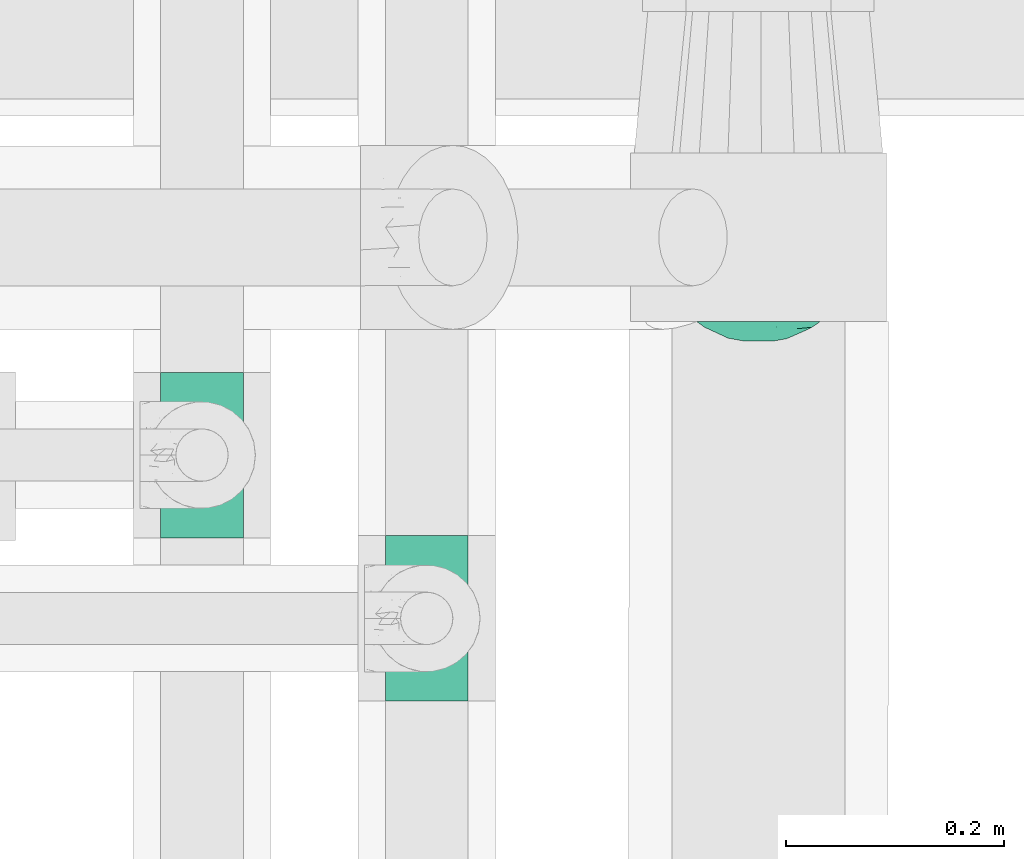
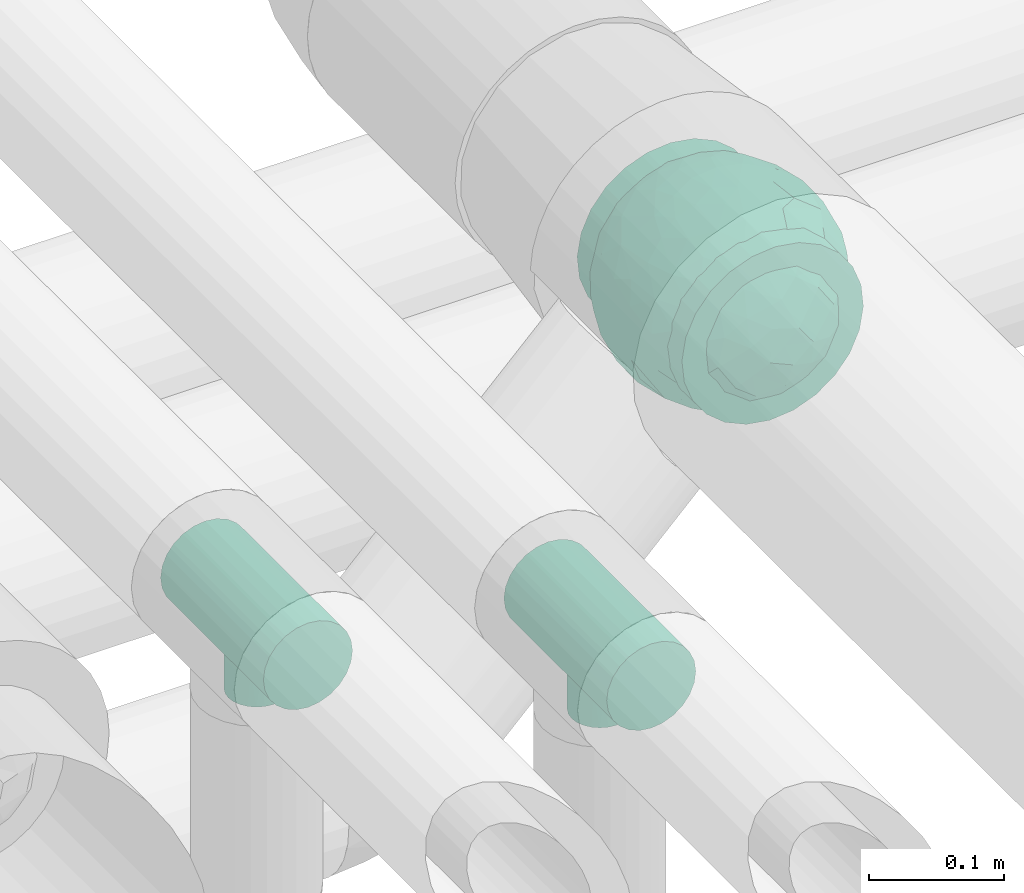
# One storey, part 68 of 93: 3 flow fittings.
"""IFC2X3 building model written with IfcOpenShell, lengths in millimetres."""

from ifc_helpers import new_model, entity, si_unit, converted_unit, derived_unit, direction, frame, origin, place, context, subcontext, project, spatial, faceted_brep, source, transform, mapped, material, material_list, type_object, type_shapes, element, save


model = new_model("IFC2X3")

# Units and contexts
model_context = context("Model", 3, precision=0.01, world=origin(), true_north=direction((6.12303176911189e-17, 1.0)))
body_context = subcontext(model_context, "Body", "Model", "MODEL_VIEW")
ifc_project = project(units=[si_unit("LENGTHUNIT", "METRE", prefix="MILLI"), si_unit("AREAUNIT", "SQUARE_METRE"), si_unit("VOLUMEUNIT", "CUBIC_METRE"), converted_unit("PLANEANGLEUNIT", "DEGREE", entity("IfcRatioMeasure", 0.0174532925199433), si_unit("PLANEANGLEUNIT", "RADIAN"), dimensions=[0, 0, 0, 0, 0, 0, 0]), si_unit("MASSUNIT", "GRAM", prefix="KILO"), derived_unit("MASSDENSITYUNIT", [(si_unit("MASSUNIT", "GRAM", prefix="KILO"), 1), (si_unit("LENGTHUNIT", "METRE"), -3)]), derived_unit("MOMENTOFINERTIAUNIT", [(si_unit("LENGTHUNIT", "METRE"), 4)]), si_unit("TIMEUNIT", "SECOND"), si_unit("FREQUENCYUNIT", "HERTZ"), si_unit("THERMODYNAMICTEMPERATUREUNIT", "DEGREE_CELSIUS"), derived_unit("THERMALTRANSMITTANCEUNIT", [(si_unit("MASSUNIT", "GRAM", prefix="KILO"), 1), (si_unit("THERMODYNAMICTEMPERATUREUNIT", "KELVIN"), -1), (si_unit("TIMEUNIT", "SECOND"), -3)]), derived_unit("VOLUMETRICFLOWRATEUNIT", [(si_unit("LENGTHUNIT", "METRE"), 3), (si_unit("TIMEUNIT", "SECOND"), -1)]), derived_unit("MASSFLOWRATEUNIT", [(si_unit("MASSUNIT", "GRAM", prefix="KILO"), 1), (si_unit("TIMEUNIT", "SECOND"), -1)]), derived_unit("ROTATIONALFREQUENCYUNIT", [(si_unit("TIMEUNIT", "SECOND"), -1)]), si_unit("ELECTRICCURRENTUNIT", "AMPERE"), si_unit("ELECTRICVOLTAGEUNIT", "VOLT"), si_unit("POWERUNIT", "WATT"), si_unit("FORCEUNIT", "NEWTON", prefix="KILO"), si_unit("ILLUMINANCEUNIT", "LUX"), si_unit("LUMINOUSFLUXUNIT", "LUMEN"), si_unit("LUMINOUSINTENSITYUNIT", "CANDELA"), derived_unit("USERDEFINED", [(si_unit("MASSUNIT", "GRAM", prefix="KILO"), -1), (si_unit("LENGTHUNIT", "METRE"), -2), (si_unit("TIMEUNIT", "SECOND"), 3), (si_unit("LUMINOUSFLUXUNIT", "LUMEN"), 1)]), derived_unit("LINEARVELOCITYUNIT", [(si_unit("LENGTHUNIT", "METRE"), 1), (si_unit("TIMEUNIT", "SECOND"), -1)]), si_unit("PRESSUREUNIT", "PASCAL"), derived_unit("USERDEFINED", [(si_unit("LENGTHUNIT", "METRE"), -2), (si_unit("MASSUNIT", "GRAM", prefix="KILO"), 1), (si_unit("TIMEUNIT", "SECOND"), -2)]), derived_unit("LINEARFORCEUNIT", [(si_unit("MASSUNIT", "GRAM", prefix="KILO"), 1), (si_unit("LENGTHUNIT", "METRE"), 1), (si_unit("TIMEUNIT", "SECOND"), -2), (si_unit("LENGTHUNIT", "METRE"), -1)]), derived_unit("PLANARFORCEUNIT", [(si_unit("MASSUNIT", "GRAM", prefix="KILO"), 1), (si_unit("LENGTHUNIT", "METRE"), 1), (si_unit("TIMEUNIT", "SECOND"), -2), (si_unit("LENGTHUNIT", "METRE"), -2)])], contexts=[model_context])

# Site, building, storey
site_placement = place(None, origin())
site = spatial("IfcSite", under=ifc_project, at=site_placement, CompositionType="ELEMENT")
building_placement = place(site_placement, origin())
building = spatial("IfcBuilding", under=site, at=building_placement, CompositionType="ELEMENT")
storey_placement = place(building_placement, frame((0.0, 0.0, -4200.0)))
storey = spatial("IfcBuildingStorey", under=building, at=storey_placement, CompositionType="ELEMENT", Elevation=-4200.0)

# Flow fittings
ifc_material_1 = material()
ifc_material_2 = material(Name="ADSK_")
ifc_material_list = material_list([ifc_material_1, ifc_material_2])
pipe_fitting_type_1 = type_object("IfcPipeFittingType", Name="ADSK_2", PredefinedType="NOTDEFINED", material=ifc_material_list)
shared_shape_1 = source(origin(), body_context, "Body", "Brep", [
    faceted_brep([(-77.5, 38.75, -67.12), (-77.5, 20.06, -74.86), (-77.5, 0.0, -77.5), (-77.5, -20.06, -74.86), (-77.5, -38.75, -67.12), (-77.5, -54.8, -54.8), (-77.5, -67.12, -38.75), (-77.5, -70.99, -29.4), (-77.5, -74.86, -20.06), (-77.5, -76.18, -10.03), (-77.5, -77.5, 0.0), (-77.5, -76.18, 10.03), (-77.5, -74.86, 20.06), (-77.5, -70.99, 29.4), (-77.5, -67.12, 38.75), (-77.5, -54.8, 54.8), (-77.5, -38.75, 67.12), (-77.5, -20.06, 74.86), (-77.5, 0.0, 77.5), (-77.5, 20.06, 74.86), (-77.5, 38.75, 67.12), (-77.5, 54.8, 54.8), (-77.5, 67.12, 38.75), (-77.5, 74.86, 20.06), (-77.5, 77.5, 0.0), (-77.5, 74.86, -20.06), (-77.5, 67.12, -38.75), (-77.5, 54.8, -54.8), (77.5, 0.0, -77.5), (77.5, 20.06, -74.86), (77.5, 38.75, -67.12), (77.5, 54.8, -54.8), (77.5, 67.12, -38.75), (77.5, 74.86, -20.06), (77.5, 77.5, 0.0), (77.5, 74.86, 20.06), (77.5, 67.12, 38.75), (77.5, 54.8, 54.8), (77.5, 38.75, 67.12), (77.5, 20.06, 74.86), (77.5, 0.0, 77.5), (77.5, -20.06, 74.86), (77.5, -38.75, 67.12), (77.5, -54.8, 54.8), (77.5, -67.12, 38.75), (77.5, -70.99, 29.4), (77.5, -74.86, 20.06), (77.5, -76.18, 10.03), (77.5, -77.5, 0.0), (77.5, -76.18, -10.03), (77.5, -74.86, -20.06), (77.5, -70.99, -29.4), (77.5, -67.12, -38.75), (77.5, -54.8, -54.8), (77.5, -38.75, -67.12), (77.5, -20.06, -74.86), (39.85, -76.08, 14.76), (41.18, -76.79, 7.38), (32.47, -72.49, 27.42), (36.16, -74.28, 21.09), (7.52, -65.24, 41.83), (42.5, -77.5, 0.0), (21.39, -68.25, 36.72), (14.46, -66.74, 39.28), (-21.4, -68.25, 36.72), (-32.48, -72.49, 27.41), (-39.86, -76.08, 14.76), (-41.18, -76.79, 7.38), (-42.5, -77.5, 0.0), (-36.17, -74.29, 21.08), (-14.46, -66.75, 39.27), (-7.53, -65.24, 41.83), (-0.01, -65.24, 41.83), (7.52, -65.24, -41.83), (-41.18, -76.79, -7.38), (21.39, -68.25, -36.72), (14.46, -66.74, -39.28), (41.18, -76.79, -7.38), (-39.86, -76.08, -14.76), (39.85, -76.08, -14.76), (36.16, -74.28, -21.09), (32.47, -72.49, -27.42), (-7.53, -65.24, -41.83), (-14.46, -66.75, -39.27), (-21.4, -68.25, -36.72), (-32.48, -72.49, -27.41), (-0.01, -65.24, -41.83), (-36.17, -74.29, -21.08), (11.0, -82.5, -41.05), (21.25, -82.5, -36.81), (30.05, -82.5, -30.05), (36.81, -82.5, -21.25), (41.05, -82.5, -11.0), (41.78, -82.5, -5.5), (42.5, -82.5, 0.0), (41.78, -82.5, 5.5), (41.05, -82.5, 11.0), (36.81, -82.5, 21.25), (30.05, -82.5, 30.05), (21.25, -82.5, 36.81), (11.0, -82.5, 41.05), (0.0, -82.5, 42.5), (-11.0, -82.5, 41.05), (-21.25, -82.5, 36.81), (-30.05, -82.5, 30.05), (-36.81, -82.5, 21.25), (-41.05, -82.5, 11.0), (-41.78, -82.5, 5.5), (-42.5, -82.5, 0.0), (-41.78, -82.5, -5.5), (-41.05, -82.5, -11.0), (-36.81, -82.5, -21.25), (-30.05, -82.5, -30.05), (-21.25, -82.5, -36.81), (-11.0, -82.5, -41.05), (0.0, -82.5, -42.5)], [[[0, 1, 2, 3, 4, 5, 6, 7, 8, 9, 10, 11, 12, 13, 14, 15, 16, 17, 18, 19, 20, 21, 22, 23, 24, 25, 26, 27]], [[28, 29, 30, 31, 32, 33, 34, 35, 36, 37, 38, 39, 40, 41, 42, 43, 44, 45, 46, 47, 48, 49, 50, 51, 52, 53, 54, 55]], [[47, 46, 56]], [[48, 47, 57]], [[46, 58, 59, 56]], [[44, 43, 60]], [[48, 57, 61]], [[58, 45, 62]], [[44, 60, 63, 62]], [[47, 56, 57]], [[43, 15, 60]], [[62, 45, 44]], [[64, 13, 65]], [[66, 11, 67]], [[68, 67, 10]], [[12, 66, 69, 65]], [[14, 64, 70, 71]], [[58, 46, 45]], [[14, 13, 64]], [[14, 71, 15]], [[65, 13, 12]], [[15, 71, 72, 60]], [[10, 67, 11]], [[66, 12, 11]], [[43, 42, 16, 15]], [[18, 17, 41, 40]], [[17, 16, 42, 41]], [[19, 18, 40, 39]], [[36, 35, 23, 22]], [[21, 20, 38, 37]], [[22, 21, 37, 36]], [[39, 38, 20, 19]], [[24, 23, 35, 34]], [[26, 25, 33, 32]], [[25, 24, 34, 33]], [[27, 26, 32, 31]], [[28, 55, 3, 2]], [[1, 0, 30, 29]], [[2, 1, 29, 28]], [[31, 30, 0, 27]], [[4, 3, 55, 54]], [[54, 53, 5, 4]], [[53, 52, 73]], [[10, 74, 68]], [[52, 75, 76, 73]], [[51, 75, 52]], [[53, 73, 5]], [[61, 77, 48]], [[9, 78, 74]], [[50, 79, 80, 81]], [[79, 49, 77]], [[75, 51, 81]], [[50, 81, 51]], [[6, 82, 83, 84]], [[85, 8, 7]], [[6, 5, 82]], [[85, 7, 84]], [[5, 73, 86, 82]], [[8, 85, 87, 78]], [[79, 50, 49]], [[78, 9, 8]], [[74, 10, 9]], [[48, 77, 49]], [[7, 6, 84]], [[88, 89, 90, 91, 92, 93, 94, 95, 96, 97, 98, 99, 100, 101, 102, 103, 104, 105, 106, 107, 108, 109, 110, 111, 112, 113, 114, 115]], [[107, 106, 67]], [[65, 105, 104]], [[106, 105, 66]], [[104, 103, 64]], [[61, 95, 94]], [[107, 68, 108]], [[66, 105, 65, 69]], [[70, 64, 103]], [[64, 65, 104]], [[101, 60, 72, 71]], [[102, 71, 70]], [[102, 70, 103]], [[68, 107, 67]], [[57, 96, 95]], [[60, 101, 100]], [[101, 71, 102]], [[58, 98, 97]], [[99, 98, 62]], [[56, 97, 96]], [[99, 63, 100]], [[98, 58, 62]], [[106, 66, 67]], [[63, 60, 100]], [[96, 57, 56]], [[59, 58, 97, 56]], [[95, 61, 57]], [[63, 99, 62]], [[93, 92, 77]], [[81, 91, 90]], [[92, 91, 79]], [[90, 89, 75]], [[68, 109, 108]], [[93, 61, 94]], [[79, 91, 81, 80]], [[76, 75, 89]], [[75, 81, 90]], [[115, 82, 86, 73]], [[83, 113, 84]], [[88, 76, 89]], [[88, 73, 76]], [[61, 93, 77]], [[82, 115, 114]], [[115, 73, 88]], [[111, 85, 112]], [[74, 110, 109]], [[113, 112, 84]], [[78, 111, 110]], [[113, 83, 114]], [[112, 85, 84]], [[92, 79, 77]], [[110, 74, 78]], [[87, 85, 111, 78]], [[109, 68, 74]], [[83, 82, 114]]]),
    faceted_brep([(74.09, -36.62, -50.54), (86.5, -25.35, -35.5), (82.61, -45.18, -22.81), (-16.75, -33.7, -89.27), (0.0, -42.78, -86.92), (-23.87, -49.97, -79.49), (73.94, -14.61, -60.86), (53.84, -28.63, -75.28), (-16.57, 93.95, 0.0), (-18.09, 86.11, -40.53), (-32.84, 86.73, -28.0), (-44.04, -10.15, -85.69), (-19.2, 4.88, -94.83), (-22.92, -15.62, -92.82), (89.65, 32.63, 0.0), (82.61, 44.34, -24.37), (83.9, 48.44, 0.0), (47.7, -82.62, 0.0), (60.26, -69.94, -29.38), (62.27, -74.21, 0.0), (95.4, 0.0, 0.0), (95.4, -16.82, 0.0), (94.13, -8.44, -21.26), (93.14, 13.95, -22.71), (95.4, 16.82, 0.0), (76.54, 8.21, -58.81), (74.09, 36.62, -50.54), (84.96, 22.7, -40.64), (28.25, -36.42, -85.21), (19.67, -61.78, -71.98), (-67.45, 51.53, -46.69), (-45.73, 54.97, -65.36), (-59.68, 42.12, -63.64), (47.7, 82.62, 0.0), (62.27, 74.21, 0.0), (59.48, 63.11, -43.18), (-48.12, -74.69, -38.62), (-33.13, -91.03, 0.0), (-47.7, -82.62, 0.0), (72.35, 57.3, -29.46), (60.01, 43.15, -62.62), (62.52, -52.48, -52.18), (45.73, -54.97, -65.36), (-62.27, -74.21, 0.0), (-73.08, -61.32, 0.0), (-72.41, -59.62, -24.21), (7.26, -81.07, -52.53), (35.35, -68.17, -59.06), (27.87, -86.63, -33.22), (-74.09, -36.62, -50.54), (-84.35, -21.79, -42.37), (-76.59, -6.33, -58.98), (61.55, 0.0, -74.81), (-61.55, 0.0, -74.81), (-79.37, 15.54, -53.33), (-95.4, -16.82, 0.0), (-92.58, -16.52, -23.25), (-89.65, -32.63, 0.0), (63.81, 22.67, -69.28), (-18.69, 68.07, -66.35), (-42.94, 76.94, -40.26), (-74.09, 36.62, -50.54), (-43.64, 36.19, -78.55), (-65.1, 21.71, -68.38), (44.46, 15.06, -84.74), (-65.04, -21.76, -68.42), (-94.63, 4.93, -20.13), (-87.93, 0.0, -40.67), (-89.65, 32.63, 0.0), (-89.27, 26.35, -26.85), (27.96, 84.78, -37.61), (7.26, 81.07, -52.53), (1.19, 92.73, -28.0), (3.41, -92.84, -27.46), (-8.28, -95.41, 0.0), (-11.9, -93.14, -23.83), (73.08, 61.32, 0.0), (87.93, 0.0, -40.67), (73.08, -61.32, 0.0), (83.9, -48.44, 0.0), (-73.08, 61.32, 0.0), (-82.24, 45.34, -23.77), (-83.9, 48.44, 0.0), (-63.57, -59.47, -42.5), (-45.73, -54.97, -65.36), (-82.58, -43.28, -26.32), (29.11, 48.1, -78.89), (45.73, 54.97, -65.36), (44.58, 36.0, -78.11), (-61.2, 65.56, -36.61), (-6.93, -65.5, -71.03), (30.56, -5.14, -91.79), (9.54, -19.86, -94.34), (0.0, 12.89, -96.01), (47.81, -10.83, -83.56), (89.65, -32.63, 0.0), (44.95, 76.64, -38.61), (33.13, 91.03, 0.0), (28.53, 69.09, -61.62), (-51.45, 14.65, -80.76), (22.17, 26.71, -90.44), (33.13, -91.03, 0.0), (44.95, -76.64, -38.61), (72.35, -57.3, -29.46), (16.57, -93.95, 0.0), (-15.25, 22.47, -92.99), (2.72, 32.92, -91.07), (8.92, 50.75, -82.03), (9.42, 67.57, -68.78), (16.57, 93.95, 0.0), (-5.45, -87.35, -41.54), (8.28, -95.41, 0.0), (0.0, -96.88, 0.0), (-24.34, -90.45, -24.71), (-25.14, -82.23, -44.62), (-16.57, -93.95, 0.0), (-9.92, -78.26, -56.23), (-30.26, -67.58, -62.46), (-40.87, -32.58, -81.57), (-34.66, 17.97, -88.66), (-59.69, -42.16, -63.59), (-16.8, 39.61, -86.8), (-28.19, 53.95, -75.36), (-10.32, 55.25, -78.9), (-57.91, -73.21, -25.92), (-83.9, -48.44, 0.0), (-95.4, 0.0, 0.0), (-95.4, 16.82, 0.0), (-72.43, 58.81, -26.08), (-62.27, 74.21, 0.0), (-47.7, 82.62, 0.0), (-33.13, 91.03, 0.0), (0.0, 96.87, 0.0), (-74.09, -36.62, 50.54), (-86.5, -25.35, 35.5), (-82.61, -45.18, 22.81), (16.75, -33.7, 89.27), (0.0, -42.78, 86.92), (23.87, -49.97, 79.49), (-73.94, -14.61, 60.86), (-53.84, -28.63, 75.28), (18.09, 86.11, 40.53), (32.84, 86.73, 28.0), (44.04, -10.15, 85.69), (19.2, 4.88, 94.83), (22.92, -15.62, 92.82), (-82.61, 44.34, 24.37), (-60.26, -69.94, 29.38), (-94.13, -8.44, 21.26), (-93.14, 13.95, 22.71), (-76.54, 8.21, 58.81), (-74.09, 36.62, 50.54), (-84.96, 22.7, 40.64), (-28.25, -36.42, 85.21), (-19.67, -61.78, 71.98), (67.45, 51.53, 46.69), (45.73, 54.97, 65.36), (59.68, 42.12, 63.64), (-28.53, 69.09, 61.62), (-45.73, 54.97, 65.36), (-29.11, 48.1, 78.89), (48.12, -74.69, 38.62), (-59.48, 63.11, 43.18), (-72.35, 57.3, 29.46), (-60.01, 43.15, 62.62), (-35.35, -68.17, 59.06), (-7.26, -81.07, 52.53), (72.41, -59.62, 24.21), (-3.41, -92.84, 27.46), (74.09, -36.62, 50.54), (84.35, -21.79, 42.37), (76.59, -6.33, 58.98), (-61.55, 0.0, 74.81), (61.55, 0.0, 74.81), (79.37, 15.54, 53.33), (92.58, -16.52, 23.25), (-63.81, 22.67, 69.28), (18.69, 68.07, 66.35), (42.94, 76.94, 40.26), (74.09, 36.62, 50.54), (43.64, 36.19, 78.55), (65.1, 21.71, 68.38), (-44.46, 15.06, 84.74), (65.04, -21.76, 68.42), (94.63, 4.93, 20.13), (87.93, 0.0, 40.67), (89.27, 26.35, 26.85), (-27.96, 84.78, 37.61), (-7.26, 81.07, 52.53), (-1.19, 92.73, 28.0), (11.9, -93.14, 23.83), (-87.93, 0.0, 40.67), (82.24, 45.34, 23.77), (63.57, -59.47, 42.5), (45.73, -54.97, 65.36), (82.58, -43.28, 26.32), (-44.58, 36.0, 78.11), (61.2, 65.56, 36.61), (25.14, -82.23, 44.62), (5.45, -87.35, 41.54), (24.34, -90.45, 24.71), (6.93, -65.5, 71.03), (-30.56, -5.14, 91.79), (-9.54, -19.86, 94.34), (0.0, 12.89, 96.01), (-47.81, -10.83, 83.56), (-44.95, 76.64, 38.61), (51.45, 14.65, 80.76), (-62.52, -52.48, 52.18), (-45.73, -54.97, 65.36), (-22.17, 26.71, 90.44), (-44.95, -76.64, 38.61), (-72.35, -57.3, 29.46), (-27.87, -86.63, 33.22), (15.25, 22.47, 92.99), (-2.72, 32.92, 91.07), (-8.92, 50.75, 82.03), (-9.42, 67.57, 68.78), (9.92, -78.26, 56.23), (30.26, -67.58, 62.46), (40.87, -32.58, 81.57), (34.66, 17.97, 88.66), (59.69, -42.16, 63.59), (16.8, 39.61, 86.8), (28.19, 53.95, 75.36), (10.32, 55.25, 78.9), (57.91, -73.21, 25.92), (72.43, 58.81, 26.08)], [[[0, 1, 2]], [[3, 4, 5]], [[6, 0, 7]], [[8, 9, 10]], [[11, 12, 13]], [[14, 15, 16]], [[17, 18, 19]], [[20, 21, 22]], [[23, 24, 20]], [[25, 26, 27]], [[4, 28, 29]], [[30, 31, 32]], [[33, 34, 35]], [[36, 37, 38]], [[35, 39, 40]], [[41, 18, 42]], [[43, 44, 45]], [[46, 47, 48]], [[49, 50, 51]], [[52, 25, 6]], [[53, 51, 54]], [[55, 56, 57]], [[26, 25, 58]], [[59, 31, 60]], [[32, 61, 30]], [[62, 63, 32]], [[52, 64, 58]], [[51, 65, 49]], [[56, 66, 67]], [[66, 68, 69]], [[70, 71, 72]], [[73, 74, 75]], [[6, 7, 52]], [[20, 22, 23]], [[76, 39, 34]], [[15, 26, 39]], [[1, 77, 22]], [[78, 2, 79]], [[61, 54, 69]], [[80, 81, 82]], [[36, 83, 84]], [[85, 56, 50]], [[86, 87, 88]], [[60, 31, 89]], [[48, 73, 46]], [[4, 29, 90]], [[91, 92, 93]], [[7, 94, 52]], [[77, 23, 22]], [[95, 79, 2]], [[0, 6, 1]], [[1, 22, 95]], [[1, 95, 2]], [[27, 23, 77]], [[15, 14, 23]], [[25, 27, 77]], [[15, 76, 16]], [[40, 39, 26]], [[39, 76, 15]], [[96, 97, 33]], [[70, 98, 71]], [[39, 35, 34]], [[87, 86, 98]], [[77, 1, 6]], [[25, 52, 58]], [[62, 99, 63]], [[26, 15, 27]], [[6, 25, 77]], [[0, 41, 7]], [[42, 28, 7]], [[92, 91, 28]], [[94, 28, 91]], [[88, 87, 40]], [[52, 94, 64]], [[40, 26, 58]], [[100, 91, 93]], [[88, 40, 58]], [[22, 21, 95]], [[101, 102, 17]], [[103, 78, 19]], [[41, 0, 103]], [[18, 102, 42]], [[101, 48, 102]], [[101, 104, 48]], [[29, 28, 42]], [[28, 4, 92]], [[102, 47, 42]], [[90, 29, 46]], [[88, 58, 64]], [[40, 87, 35]], [[87, 96, 35]], [[33, 35, 96]], [[100, 64, 91]], [[88, 64, 100]], [[12, 105, 93]], [[98, 96, 87]], [[106, 100, 93]], [[86, 100, 107]], [[100, 86, 88]], [[98, 108, 71]], [[108, 86, 107]], [[109, 70, 72]], [[70, 109, 97]], [[96, 98, 70]], [[97, 96, 70]], [[78, 103, 2]], [[0, 2, 103]], [[41, 103, 18]], [[7, 41, 42]], [[19, 18, 103]], [[102, 18, 17]], [[75, 110, 73]], [[73, 104, 111, 112]], [[113, 114, 110]], [[115, 75, 74]], [[36, 114, 37]], [[90, 5, 4]], [[73, 48, 104]], [[47, 46, 29]], [[46, 116, 90]], [[5, 117, 84]], [[90, 116, 117]], [[118, 13, 3]], [[118, 5, 84]], [[11, 119, 12]], [[65, 120, 49]], [[11, 13, 118]], [[63, 53, 54]], [[121, 122, 123]], [[90, 117, 5]], [[49, 120, 83]], [[117, 36, 84]], [[36, 117, 114]], [[43, 45, 124]], [[38, 124, 36]], [[83, 124, 45]], [[85, 125, 57]], [[125, 85, 44]], [[45, 49, 83]], [[66, 55, 126, 127]], [[57, 56, 85]], [[56, 67, 50]], [[51, 50, 67]], [[85, 50, 49]], [[54, 51, 67]], [[51, 53, 65]], [[69, 54, 67]], [[54, 61, 63]], [[69, 67, 66]], [[128, 129, 89]], [[11, 65, 53]], [[120, 118, 84]], [[32, 63, 61]], [[99, 53, 63]], [[118, 120, 65]], [[83, 120, 84]], [[129, 128, 80]], [[62, 32, 31]], [[60, 130, 131]], [[130, 60, 89]], [[9, 71, 59]], [[10, 60, 131]], [[108, 59, 71]], [[71, 9, 72]], [[62, 121, 119]], [[122, 59, 123]], [[62, 119, 99]], [[62, 31, 122]], [[106, 107, 100]], [[44, 85, 45]], [[49, 45, 85]], [[55, 66, 56]], [[62, 122, 121]], [[89, 129, 130]], [[65, 11, 118]], [[11, 53, 99]], [[80, 128, 81]], [[30, 128, 89]], [[81, 61, 69]], [[61, 81, 128]], [[82, 81, 69]], [[10, 59, 60]], [[72, 8, 132]], [[8, 72, 9]], [[109, 72, 132]], [[3, 92, 4]], [[92, 13, 12]], [[23, 27, 15]], [[14, 24, 23]], [[11, 99, 119]], [[128, 30, 61]], [[31, 30, 89]], [[28, 94, 7]], [[64, 94, 91]], [[48, 47, 102]], [[29, 42, 47]], [[105, 106, 93]], [[123, 106, 121]], [[86, 108, 98]], [[108, 107, 123]], [[73, 112, 74]], [[113, 75, 115]], [[114, 116, 110]], [[115, 37, 113]], [[37, 114, 113]], [[46, 73, 110]], [[117, 116, 114]], [[110, 75, 113]], [[46, 110, 116]], [[118, 3, 5]], [[92, 3, 13]], [[105, 119, 121]], [[92, 12, 93]], [[119, 105, 12]], [[106, 105, 121]], [[43, 124, 38]], [[83, 36, 124]], [[68, 66, 127]], [[68, 82, 69]], [[31, 59, 122]], [[108, 123, 59]], [[106, 123, 107]], [[8, 10, 131]], [[59, 10, 9]], [[133, 134, 135]], [[136, 137, 138]], [[139, 133, 140]], [[109, 141, 142]], [[143, 144, 145]], [[68, 146, 82]], [[38, 147, 43]], [[148, 126, 55]], [[149, 127, 126]], [[150, 151, 152]], [[137, 153, 154]], [[155, 156, 157]], [[158, 159, 160]], [[161, 101, 17]], [[162, 163, 164]], [[154, 165, 166]], [[19, 78, 167]], [[168, 115, 74, 112]], [[169, 170, 171]], [[172, 150, 139]], [[173, 171, 174]], [[21, 175, 95]], [[151, 150, 176]], [[177, 156, 178]], [[157, 179, 155]], [[180, 181, 157]], [[172, 182, 176]], [[171, 183, 169]], [[175, 184, 185]], [[186, 24, 14, 16]], [[187, 188, 189]], [[168, 111, 190]], [[139, 140, 172]], [[126, 148, 149]], [[80, 163, 129]], [[146, 151, 163]], [[134, 191, 148]], [[44, 135, 125]], [[179, 174, 186]], [[76, 192, 16]], [[161, 193, 194]], [[195, 175, 170]], [[160, 159, 196]], [[178, 156, 197]], [[198, 199, 200]], [[137, 154, 201]], [[202, 203, 204]], [[140, 205, 172]], [[134, 133, 139]], [[125, 135, 57]], [[148, 191, 149]], [[134, 148, 57]], [[134, 57, 135]], [[152, 149, 191]], [[146, 68, 149]], [[150, 152, 191]], [[146, 80, 82]], [[164, 163, 151]], [[163, 80, 146]], [[162, 130, 129]], [[130, 206, 131]], [[163, 162, 129]], [[158, 188, 187]], [[191, 134, 139]], [[150, 172, 176]], [[180, 207, 181]], [[151, 146, 152]], [[139, 150, 191]], [[133, 208, 140]], [[209, 153, 140]], [[203, 202, 153]], [[205, 153, 202]], [[196, 159, 164]], [[172, 205, 182]], [[164, 151, 176]], [[210, 202, 204]], [[196, 164, 176]], [[148, 55, 57]], [[38, 37, 211]], [[212, 44, 43]], [[208, 133, 212]], [[147, 211, 209]], [[165, 213, 166]], [[209, 208, 147]], [[154, 153, 209]], [[153, 137, 203]], [[211, 165, 209]], [[201, 154, 166]], [[196, 176, 182]], [[164, 159, 162]], [[159, 206, 162]], [[130, 162, 206]], [[210, 182, 202]], [[196, 182, 210]], [[144, 214, 204]], [[158, 206, 159]], [[215, 210, 204]], [[160, 210, 216]], [[210, 160, 196]], [[158, 217, 188]], [[217, 160, 216]], [[8, 187, 189]], [[187, 8, 131]], [[206, 158, 187]], [[131, 206, 187]], [[44, 212, 135]], [[133, 135, 212]], [[208, 212, 147]], [[140, 208, 209]], [[43, 147, 212]], [[211, 147, 38]], [[199, 168, 190]], [[213, 115, 168]], [[213, 168, 166]], [[104, 190, 111]], [[161, 198, 101]], [[201, 138, 137]], [[37, 115, 213]], [[211, 37, 213]], [[166, 218, 201]], [[138, 219, 194]], [[201, 218, 219]], [[220, 145, 136]], [[220, 138, 194]], [[143, 221, 144]], [[183, 222, 169]], [[143, 145, 220]], [[181, 173, 174]], [[223, 224, 225]], [[201, 219, 138]], [[169, 222, 193]], [[219, 161, 194]], [[161, 219, 198]], [[19, 167, 226]], [[17, 226, 161]], [[193, 226, 167]], [[195, 79, 95]], [[79, 195, 78]], [[167, 169, 193]], [[184, 21, 20, 24]], [[95, 175, 195]], [[175, 185, 170]], [[171, 170, 185]], [[195, 170, 169]], [[174, 171, 185]], [[171, 173, 183]], [[186, 174, 185]], [[174, 179, 181]], [[186, 185, 184]], [[227, 34, 197]], [[143, 183, 173]], [[222, 220, 194]], [[157, 181, 179]], [[207, 173, 181]], [[220, 222, 183]], [[193, 222, 194]], [[34, 227, 76]], [[180, 157, 156]], [[178, 33, 97]], [[33, 178, 197]], [[141, 188, 177]], [[142, 178, 97]], [[217, 177, 188]], [[188, 141, 189]], [[180, 223, 221]], [[224, 177, 225]], [[180, 221, 207]], [[180, 156, 224]], [[215, 216, 210]], [[78, 195, 167]], [[169, 167, 195]], [[21, 184, 175]], [[186, 184, 24]], [[197, 34, 33]], [[183, 143, 220]], [[143, 173, 207]], [[76, 227, 192]], [[155, 227, 197]], [[192, 179, 186]], [[179, 192, 227]], [[16, 192, 186]], [[142, 177, 178]], [[189, 109, 132]], [[109, 189, 141]], [[8, 189, 132]], [[136, 203, 137]], [[203, 145, 144]], [[149, 152, 146]], [[68, 127, 149]], [[143, 207, 221]], [[227, 155, 179]], [[156, 155, 197]], [[153, 205, 140]], [[182, 205, 202]], [[213, 165, 211]], [[154, 209, 165]], [[214, 215, 204]], [[225, 215, 223]], [[160, 217, 158]], [[217, 216, 225]], [[168, 112, 111]], [[200, 190, 104]], [[198, 218, 199]], [[104, 101, 200]], [[101, 198, 200]], [[166, 168, 199]], [[219, 218, 198]], [[199, 190, 200]], [[166, 199, 218]], [[220, 136, 138]], [[203, 136, 145]], [[214, 221, 223]], [[203, 144, 204]], [[221, 214, 144]], [[215, 214, 223]], [[19, 226, 17]], [[193, 161, 226]], [[180, 224, 223]], [[156, 177, 224]], [[217, 225, 177]], [[215, 225, 216]], [[109, 142, 97]], [[177, 142, 141]]]),
])
type_shapes(pipe_fitting_type_1, [shared_shape_1])
flow_fitting_placement = place(storey_placement, frame((24979.3, 9061.14, 3000.0), z_axis=(-0.683987608829283, 0.0, 0.729493626406701), x_axis=(0.0, -1.0, 0.0)))
element("IfcFlowFitting", 1, at=flow_fitting_placement, inside=storey, type_object=pipe_fitting_type_1, material=ifc_material_list, Name="ADSK_2", ObjectType="ADSK_2", context=body_context, shape_type="MappedRepresentation", body=[
    mapped(shared_shape_1, transform((0.0, 0.0, 0.0), scale=1.0)),
])
pipe_fitting_type_2 = type_object("IfcPipeFittingType", Name="ADSK_1", PredefinedType="NOTDEFINED", material=ifc_material_1)
shared_shape_2 = source(origin(), body_context, "Body", "Brep", [
    faceted_brep([(-76.0, 9.85, -36.75), (-76.0, 0.0, -38.05), (-76.0, -9.85, -36.75), (-76.0, -19.03, -32.95), (-76.0, -26.91, -26.91), (-76.0, -32.95, -19.03), (-76.0, -36.75, -9.85), (-76.0, -38.05, 0.0), (-76.0, -36.75, 9.85), (-76.0, -32.95, 19.02), (-76.0, -26.91, 26.91), (-76.0, -19.03, 32.95), (-76.0, -9.85, 36.75), (-76.0, 0.0, 38.05), (-76.0, 9.85, 36.75), (-76.0, 19.02, 32.95), (-76.0, 26.91, 26.91), (-76.0, 32.95, 19.02), (-76.0, 36.75, 9.85), (-76.0, 38.05, 0.0), (-76.0, 36.75, -9.85), (-76.0, 32.95, -19.03), (-76.0, 26.91, -26.91), (-76.0, 19.02, -32.95), (76.0, 26.91, -26.91), (76.0, 32.95, -19.03), (76.0, 36.75, -9.85), (76.0, 38.05, 0.0), (76.0, 36.75, 9.85), (76.0, 32.95, 19.02), (76.0, 26.91, 26.91), (76.0, 19.02, 32.95), (76.0, 9.85, 36.75), (76.0, 0.0, 38.05), (76.0, -9.85, 36.75), (76.0, -19.03, 32.95), (76.0, -26.91, 26.91), (76.0, -32.95, 19.02), (76.0, -36.75, 9.85), (76.0, -38.05, 0.0), (76.0, -36.75, -9.85), (76.0, -32.95, -19.03), (76.0, -26.91, -26.91), (76.0, -19.03, -32.95), (76.0, -9.85, -36.75), (76.0, 0.0, -38.05), (76.0, 9.85, -36.75), (76.0, 19.02, -32.95), (22.62, -37.1, 8.45), (23.39, -37.58, 4.22), (24.15, -38.05, 0.0), (18.42, -34.7, 15.61), (4.31, -29.72, 23.76), (12.18, -31.83, 20.86), (8.24, -30.77, 22.31), (-24.15, -38.05, 0.0), (-23.39, -37.58, 4.22), (-22.63, -37.1, 8.44), (-18.43, -34.7, 15.61), (-12.18, -31.83, 20.85), (-4.31, -29.72, 23.76), (0.0, -29.72, 23.76), (4.31, -29.72, -23.76), (12.18, -31.83, -20.86), (8.24, -30.77, -22.31), (18.42, -34.7, -15.61), (22.62, -37.1, -8.45), (23.39, -37.58, -4.22), (-4.31, -29.72, -23.76), (-12.18, -31.83, -20.85), (-18.43, -34.7, -15.61), (0.0, -29.72, -23.76), (-22.63, -37.1, -8.44), (-23.39, -37.58, -4.22), (0.0, -67.0, -24.15), (6.25, -67.0, -23.33), (12.08, -67.0, -20.91), (17.08, -67.0, -17.08), (20.91, -67.0, -12.08), (23.33, -67.0, -6.25), (24.15, -67.0, 0.0), (23.33, -67.0, 6.25), (20.91, -67.0, 12.07), (17.08, -67.0, 17.08), (12.08, -67.0, 20.91), (6.25, -67.0, 23.33), (0.0, -67.0, 24.15), (-6.25, -67.0, 23.33), (-12.07, -67.0, 20.91), (-17.08, -67.0, 17.08), (-20.91, -67.0, 12.07), (-23.33, -67.0, 6.25), (-24.15, -67.0, 0.0), (-23.33, -67.0, -6.25), (-20.91, -67.0, -12.08), (-17.08, -67.0, -17.08), (-12.07, -67.0, -20.91), (-6.25, -67.0, -23.33)], [[[0, 1, 2, 3, 4, 5, 6, 7, 8, 9, 10, 11, 12, 13, 14, 15, 16, 17, 18, 19, 20, 21, 22, 23]], [[24, 25, 26, 27, 28, 29, 30, 31, 32, 33, 34, 35, 36, 37, 38, 39, 40, 41, 42, 43, 44, 45, 46, 47]], [[39, 38, 48]], [[39, 48, 49, 50]], [[38, 51, 48]], [[37, 36, 52]], [[53, 51, 37]], [[37, 52, 54, 53]], [[36, 10, 52]], [[37, 51, 38]], [[7, 55, 56, 57]], [[8, 7, 57]], [[57, 58, 8]], [[59, 60, 9]], [[59, 9, 58]], [[9, 60, 10]], [[58, 9, 8]], [[10, 60, 61, 52]], [[36, 35, 11, 10]], [[13, 12, 34, 33]], [[12, 11, 35, 34]], [[14, 13, 33, 32]], [[29, 28, 18, 17]], [[16, 15, 31, 30]], [[17, 16, 30, 29]], [[32, 31, 15, 14]], [[19, 18, 28, 27]], [[26, 25, 21, 20]], [[25, 24, 22, 21]], [[27, 26, 20, 19]], [[45, 44, 2, 1]], [[0, 23, 47, 46]], [[1, 0, 46, 45]], [[24, 47, 23, 22]], [[3, 2, 44, 43]], [[43, 42, 4, 3]], [[42, 41, 62]], [[41, 63, 64, 62]], [[41, 65, 63]], [[42, 62, 4]], [[40, 39, 66]], [[66, 65, 40]], [[39, 50, 67, 66]], [[40, 65, 41]], [[68, 69, 5]], [[5, 4, 68]], [[69, 70, 5]], [[4, 62, 71, 68]], [[70, 72, 6]], [[72, 7, 6]], [[7, 72, 73, 55]], [[70, 6, 5]], [[74, 75, 76, 77, 78, 79, 80, 81, 82, 83, 84, 85, 86, 87, 88, 89, 90, 91, 92, 93, 94, 95, 96, 97]], [[56, 92, 91]], [[86, 60, 87]], [[59, 89, 88]], [[84, 54, 85]], [[49, 80, 50]], [[59, 88, 87]], [[49, 48, 81]], [[91, 57, 56]], [[55, 92, 56]], [[57, 91, 90]], [[57, 90, 58]], [[89, 58, 90]], [[89, 59, 58]], [[87, 60, 59]], [[86, 52, 61, 60]], [[84, 53, 54]], [[83, 53, 84]], [[48, 82, 81]], [[83, 82, 51]], [[52, 86, 85]], [[54, 52, 85]], [[53, 83, 51]], [[51, 82, 48]], [[80, 49, 81]], [[79, 67, 80]], [[77, 65, 78]], [[64, 76, 75]], [[79, 66, 67]], [[78, 66, 79]], [[63, 77, 76]], [[67, 50, 80]], [[66, 78, 65]], [[75, 62, 64]], [[63, 65, 77]], [[74, 68, 71, 62]], [[74, 62, 75]], [[73, 92, 55]], [[69, 97, 96]], [[73, 72, 93]], [[95, 69, 96]], [[72, 94, 93]], [[95, 94, 70]], [[68, 74, 97]], [[97, 69, 68]], [[69, 95, 70]], [[70, 94, 72]], [[92, 73, 93]], [[64, 63, 76]]]),
])
type_shapes(pipe_fitting_type_2, [shared_shape_2])
for number, where, z_axis, x_axis, name in (
    (2, (24468.05, 8861.14, 3000.0), (-1.0, 0.0, 0.0), (0.0, -1.0, 0.0), "ADSK_1"),
    (3, (24674.46, 8711.14, 3000.0), (-1.0, 0.0, 0.0), (0.0, -1.0, 0.0), "ADSK_1"),
):
    element("IfcFlowFitting", number, at=place(storey_placement, frame(where, z_axis=z_axis, x_axis=x_axis)), inside=storey, type_object=pipe_fitting_type_2, material=ifc_material_1, Name=name, ObjectType="ADSK_1", context=body_context, shape_type="MappedRepresentation", body=[
        mapped(shared_shape_2, transform((0.0, 0.0, 0.0), scale=1.0)),
    ])

save(model, "model.ifc")
